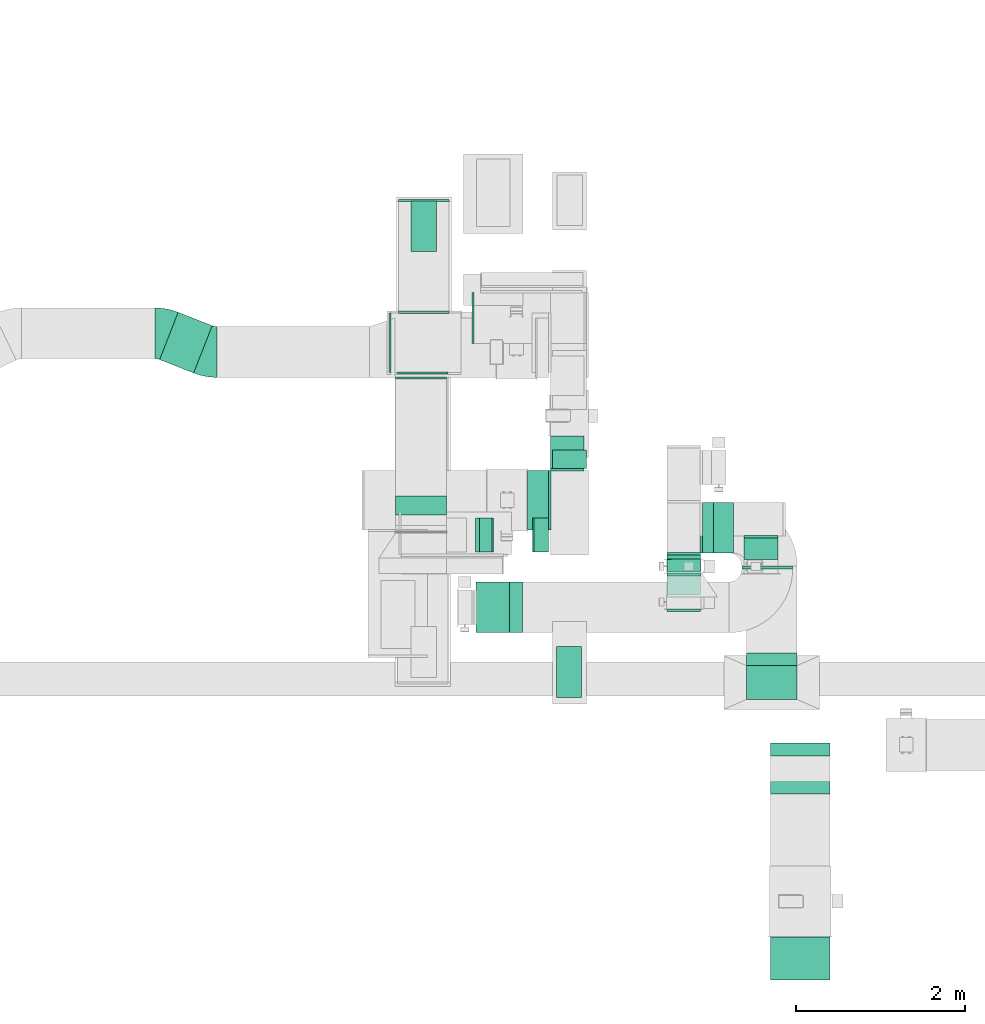
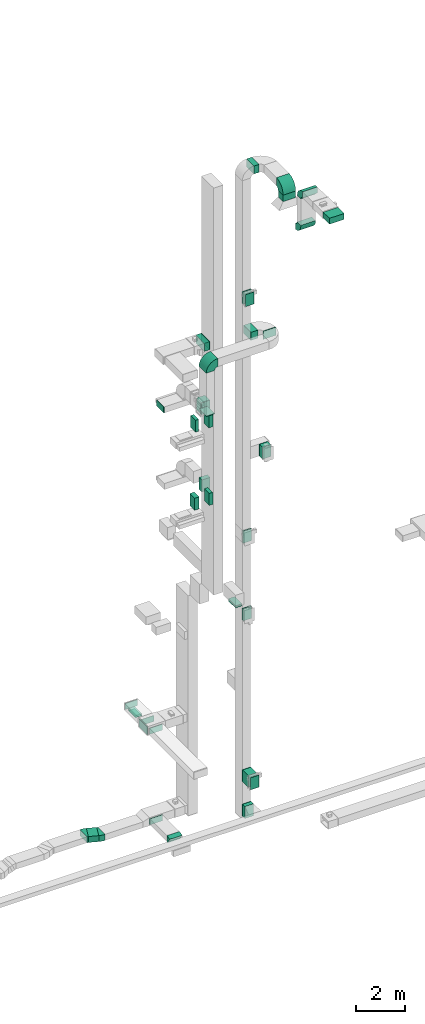
# One storey, part 13 of 29: 27 flow fittings, 21 flow segments, 1 flow terminal.
"""IFC2X3 building model written with IfcOpenShell, lengths in millimetres."""

from ifc_helpers import new_model, entity, si_unit, converted_unit, derived_unit, direction, frame, frame_2d, origin, origin_2d_with_axis, place, context, subcontext, project, spatial, polyline, circle_curve, parameter, trimmed, segment, composite_curve, rectangle, outline, extrude, source, transform, mapped, material, type_object, type_shapes, element, save


model = new_model("IFC2X3")

# Units and contexts
model_context = context("Model", 3, precision=0.01, world=origin(), true_north=direction((6.12303176911189e-17, 1.0)))
body_context = subcontext(model_context, "Body", "Model", "MODEL_VIEW")
ifc_project = project(units=[si_unit("LENGTHUNIT", "METRE", prefix="MILLI"), si_unit("AREAUNIT", "SQUARE_METRE"), si_unit("VOLUMEUNIT", "CUBIC_METRE"), converted_unit("PLANEANGLEUNIT", "DEGREE", entity("IfcRatioMeasure", 0.0174532925199433), si_unit("PLANEANGLEUNIT", "RADIAN"), dimensions=[0, 0, 0, 0, 0, 0, 0]), si_unit("MASSUNIT", "GRAM", prefix="KILO"), derived_unit("MASSDENSITYUNIT", [(si_unit("MASSUNIT", "GRAM", prefix="KILO"), 1), (si_unit("LENGTHUNIT", "METRE"), -3)]), derived_unit("MOMENTOFINERTIAUNIT", [(si_unit("LENGTHUNIT", "METRE"), 4)]), si_unit("TIMEUNIT", "SECOND"), si_unit("FREQUENCYUNIT", "HERTZ"), si_unit("THERMODYNAMICTEMPERATUREUNIT", "DEGREE_CELSIUS"), derived_unit("THERMALTRANSMITTANCEUNIT", [(si_unit("MASSUNIT", "GRAM", prefix="KILO"), 1), (si_unit("THERMODYNAMICTEMPERATUREUNIT", "KELVIN"), -1), (si_unit("TIMEUNIT", "SECOND"), -3)]), derived_unit("VOLUMETRICFLOWRATEUNIT", [(si_unit("LENGTHUNIT", "METRE"), 3), (si_unit("TIMEUNIT", "SECOND"), -1)]), derived_unit("MASSFLOWRATEUNIT", [(si_unit("MASSUNIT", "GRAM", prefix="KILO"), 1), (si_unit("TIMEUNIT", "SECOND"), -1)]), derived_unit("ROTATIONALFREQUENCYUNIT", [(si_unit("TIMEUNIT", "SECOND"), -1)]), si_unit("ELECTRICCURRENTUNIT", "AMPERE"), si_unit("ELECTRICVOLTAGEUNIT", "VOLT"), si_unit("POWERUNIT", "WATT"), si_unit("FORCEUNIT", "NEWTON", prefix="KILO"), si_unit("ILLUMINANCEUNIT", "LUX"), si_unit("LUMINOUSFLUXUNIT", "LUMEN"), si_unit("LUMINOUSINTENSITYUNIT", "CANDELA"), derived_unit("USERDEFINED", [(si_unit("MASSUNIT", "GRAM", prefix="KILO"), -1), (si_unit("LENGTHUNIT", "METRE"), -2), (si_unit("TIMEUNIT", "SECOND"), 3), (si_unit("LUMINOUSFLUXUNIT", "LUMEN"), 1)]), derived_unit("LINEARVELOCITYUNIT", [(si_unit("LENGTHUNIT", "METRE"), 1), (si_unit("TIMEUNIT", "SECOND"), -1)]), si_unit("PRESSUREUNIT", "PASCAL"), derived_unit("USERDEFINED", [(si_unit("LENGTHUNIT", "METRE"), -2), (si_unit("MASSUNIT", "GRAM", prefix="KILO"), 1), (si_unit("TIMEUNIT", "SECOND"), -2)]), derived_unit("LINEARFORCEUNIT", [(si_unit("MASSUNIT", "GRAM", prefix="KILO"), 1), (si_unit("LENGTHUNIT", "METRE"), 1), (si_unit("TIMEUNIT", "SECOND"), -2), (si_unit("LENGTHUNIT", "METRE"), -1)]), derived_unit("PLANARFORCEUNIT", [(si_unit("MASSUNIT", "GRAM", prefix="KILO"), 1), (si_unit("LENGTHUNIT", "METRE"), 1), (si_unit("TIMEUNIT", "SECOND"), -2), (si_unit("LENGTHUNIT", "METRE"), -2)])], contexts=[model_context])

# Site, building, storey
site_placement = place(None, frame((0.0, -0.00077364408347762, 0.0)))
site = spatial("IfcSite", under=ifc_project, at=site_placement, CompositionType="ELEMENT")
building_placement = place(site_placement, origin())
building = spatial("IfcBuilding", under=site, at=building_placement, CompositionType="ELEMENT")
storey_placement = place(building_placement, origin())
storey = spatial("IfcBuildingStorey", under=building, at=storey_placement, CompositionType="ELEMENT", Elevation=0.0)

# Flow segments
duct_segment_type = type_object("IfcDuctSegmentType", PredefinedType="NOTDEFINED")
flow_segment_1_placement = place(storey_placement, frame((30023.9052184742, 10939.6152449868, 22300.0)))
element("IfcFlowSegment", 1, at=flow_segment_1_placement, inside=storey, type_object=duct_segment_type, context=body_context, shape_type="SweptSolid", body=[
    extrude(rectangle(XDim=251.096000000203, YDim=699.999999999999, at=frame_2d((2.16715534406831e-12, 1.08002495835535e-12), x_axis=(1.0, 0.0))), frame((125.548000000099, 350.0, 0.0)), (0.0, 0.0, 1.0), 399.999999999996),
])
flow_segment_2_placement = place(storey_placement, frame((29456.9164691885, 10677.382032688, 18600.0)))
element("IfcFlowSegment", 2, at=flow_segment_2_placement, inside=storey, type_object=duct_segment_type, context=body_context, shape_type="SweptSolid", body=[
    extrude(rectangle(XDim=150.000000000005, YDim=400.0, at=frame_2d((-2.16715534406831e-12, 0.0), x_axis=(1.0, 0.0))), frame((75.0, 200.0, 0.0), z_axis=(0.0, 0.0, 1.0), x_axis=(-1.0, 0.0, 0.0)), (0.0, 0.0, 1.0), 599.999999999998),
])
flow_segment_3_placement = place(storey_placement, frame((30086.9164691886, 10677.382032688, 18600.0)))
element("IfcFlowSegment", 3, at=flow_segment_3_placement, inside=storey, type_object=duct_segment_type, context=body_context, shape_type="SweptSolid", body=[
    extrude(rectangle(XDim=188.084749285835, YDim=400.0, at=frame_2d((-2.16715534406831e-12, 0.0), x_axis=(1.0, 0.0))), frame((94.0423746429199, 200.0, 0.0), z_axis=(0.0, 0.0, 1.0), x_axis=(-1.0, 0.0, 0.0)), (0.0, 0.0, 1.0), 600.000000000002),
])
flow_segment_4_placement = place(storey_placement, frame((30101.9164691886, 10677.382032688, 14700.0)))
element("IfcFlowSegment", 4, at=flow_segment_4_placement, inside=storey, type_object=duct_segment_type, context=body_context, shape_type="SweptSolid", body=[
    extrude(rectangle(XDim=173.084749285813, YDim=400.0, at=frame_2d((2.1600499167107e-12, 0.0), x_axis=(1.0, 0.0))), frame((86.5423746429043, 200.0, 0.0), z_axis=(0.0, 0.0, 1.0), x_axis=(-1.0, 0.0, 0.0)), (0.0, 0.0, 1.0), 600.000000000002),
])
flow_segment_5_placement = place(storey_placement, frame((30365.0012184742, 8960.32523278362, 10500.0)))
element("IfcFlowSegment", 5, at=flow_segment_5_placement, inside=storey, type_object=duct_segment_type, context=body_context, shape_type="SweptSolid", body=[
    extrude(rectangle(XDim=300.000000000001, YDim=600.0, at=origin_2d_with_axis()), frame((150.0, 300.0, 0.0)), (0.0, 0.0, 1.0), 79.9999999999688),
])
flow_segment_6_placement = place(storey_placement, frame((30320.0012184742, 11661.5757001357, 14700.0)))
element("IfcFlowSegment", 6, at=flow_segment_6_placement, inside=storey, type_object=duct_segment_type, context=body_context, shape_type="SweptSolid", body=[
    extrude(rectangle(XDim=221.175631375204, YDim=400.0, at=frame_2d((-1.08002495835535e-12, 0.0), x_axis=(1.0, 0.0))), frame((200.0, 110.587815687765, 0.0), z_axis=(0.0, 0.0, 1.0), x_axis=(0.0, 1.0, 0.0)), (0.0, 0.0, 1.0), 600.000000000002),
])
flow_segment_7_placement = place(storey_placement, frame((30295.0012184743, 11661.8364765241, 18600.0)))
element("IfcFlowSegment", 7, at=flow_segment_7_placement, inside=storey, type_object=duct_segment_type, context=body_context, shape_type="SweptSolid", body=[
    extrude(rectangle(XDim=384.504473210767, YDim=400.0, at=frame_2d((1.09423581307055e-12, 0.0), x_axis=(1.0, 0.0))), frame((200.0, 192.25223660548, 0.0), z_axis=(0.0, 0.0, 1.0), x_axis=(0.0, -1.0, 0.0)), (0.0, 0.0, 1.0), 600.000000000002),
])
flow_segment_8_placement = place(storey_placement, frame((28651.0506788633, 14225.0082537764, 2400.0)))
element("IfcFlowSegment", 8, at=flow_segment_8_placement, inside=storey, type_object=duct_segment_type, context=body_context, shape_type="SweptSolid", body=[
    extrude(rectangle(XDim=599.999999999998, YDim=300.000000000001, at=frame_2d((-1.08002495835535e-12, 0.0), x_axis=(1.0, 0.0))), frame((150.0, 300.0, 0.0), z_axis=(0.0, 0.0, 1.0), x_axis=(0.0, 1.0, 0.0)), (0.0, 0.0, 1.0), 79.9999999999699),
])
flow_segment_9_placement = place(storey_placement, frame((32219.8749445683, 10665.0950531597, 30605.4908940358)))
element("IfcFlowSegment", 9, at=flow_segment_9_placement, inside=storey, type_object=duct_segment_type, context=body_context, shape_type="SweptSolid", body=[
    extrude(rectangle(XDim=239.145151963278, YDim=600.0, at=frame_2d((0.0, 1.08002495835535e-12), x_axis=(1.0, 0.0))), frame((119.572575981639, 300.0, 0.0)), (0.0, 0.0, 1.0), 399.999999999996),
])
flow_segment_10_placement = place(storey_placement, frame((31669.8749543007, 10592.3611346102, 24300.0)))
element("IfcFlowSegment", 10, at=flow_segment_10_placement, inside=storey, type_object=duct_segment_type, context=body_context, shape_type="SweptSolid", body=[
    extrude(rectangle(XDim=52.6715277765037, YDim=400.000000000002, at=frame_2d((-1.77635683940025e-15, -4.33431068813661e-12), x_axis=(1.0, 0.0))), frame((200.008206148523, 26.3981559428123, 0.0), z_axis=(0.0, 0.0, 1.0), x_axis=(0.000311966680507818, -0.999999951338394, 0.0)), (0.0, 0.0, 1.0), 600.000000000002),
])
flow_segment_11_placement = place(storey_placement, frame((32089.8749445684, 10665.0950531597, 22300.0)))
element("IfcFlowSegment", 11, at=flow_segment_11_placement, inside=storey, type_object=duct_segment_type, context=body_context, shape_type="SweptSolid", body=[
    extrude(rectangle(XDim=315.331551336668, YDim=600.0, at=frame_2d((2.1600499167107e-12, 1.08002495835535e-12), x_axis=(1.0, 0.0))), frame((157.665775668336, 300.0, 0.0), z_axis=(0.0, 0.0, 1.0), x_axis=(-1.0, 0.0, 0.0)), (0.0, 0.0, 1.0), 399.999999999996),
])
flow_segment_12_placement = place(storey_placement, frame((32555.206495905, 10474.9425362381, 22300.0)))
element("IfcFlowSegment", 12, at=flow_segment_12_placement, inside=storey, type_object=duct_segment_type, context=body_context, shape_type="SweptSolid", body=[
    extrude(rectangle(XDim=40.1525169212813, YDim=600.000000000002, at=origin_2d_with_axis()), frame((300.0, 20.0762584608995, 0.0), z_axis=(0.0, 0.0, 1.0), x_axis=(0.0, 1.0, 0.0)), (0.0, 0.0, 1.0), 399.999999999996),
])
flow_segment_13_placement = place(storey_placement, frame((32581.6142462298, 10592.0421268196, 16200.0)))
element("IfcFlowSegment", 13, at=flow_segment_13_placement, inside=storey, type_object=duct_segment_type, context=body_context, shape_type="SweptSolid", body=[
    extrude(rectangle(XDim=253.039939388961, YDim=399.999999999998, at=frame_2d((0.0, -2.17426077142591e-12), x_axis=(1.0, 0.0))), frame((200.008215459153, 126.5329569124, 0.0), z_axis=(0.0, 0.0, 1.0), x_axis=(6.49374233861676e-05, -0.999999997891566, 0.0)), (0.0, 0.0, 1.0), 599.999999999998),
])
flow_segment_14_placement = place(storey_placement, frame((31669.8796384443, 10594.9524921079, 12300.0)))
element("IfcFlowSegment", 14, at=flow_segment_14_placement, inside=storey, type_object=duct_segment_type, context=body_context, shape_type="SweptSolid", body=[
    extrude(rectangle(XDim=50.0956791701616, YDim=400.000000000001, at=frame_2d((2.16537898722891e-12, 2.1600499167107e-12), x_axis=(1.0, 0.0))), frame((200.005866195224, 25.0947227044576, 0.0), z_axis=(0.0, 0.0, 1.0), x_axis=(0.000234419037960343, -0.999999972523857, 0.0)), (0.0, 0.0, 1.0), 599.999999999998),
])
flow_segment_15_placement = place(storey_placement, frame((31669.8749446897, 10172.2318814283, 300.0)))
element("IfcFlowSegment", 15, at=flow_segment_15_placement, inside=storey, type_object=duct_segment_type, context=body_context, shape_type="SweptSolid", body=[
    extrude(rectangle(XDim=471.797025863042, YDim=400.000000000001, at=frame_2d((-1.08002495835535e-12, 4.33431068813661e-12), x_axis=(1.0, 0.0))), frame((200.008215759532, 235.905478394751, 0.0), z_axis=(0.0, 0.0, 1.0), x_axis=(3.48280314986155e-05, -1.0, 0.0)), (0.0, 0.0, 1.0), 600.0),
])
flow_segment_16_placement = place(storey_placement, frame((31669.8749445682, 10445.0, -1425.0)))
element("IfcFlowSegment", 16, at=flow_segment_16_placement, inside=storey, type_object=duct_segment_type, context=body_context, shape_type="SweptSolid", body=[
    extrude(rectangle(XDim=200.095053159419, YDim=400.0, at=frame_2d((0.0, -2.17426077142591e-12), x_axis=(1.0, 0.0))), frame((200.0, 100.04752657971, 0.0), z_axis=(0.0, 0.0, 1.0), x_axis=(0.0, 1.0, 0.0)), (0.0, 0.0, 1.0), 600.0),
])
flow_segment_17_placement = place(storey_placement, frame((32894.0200965316, 5624.99997688055, 30900.0)))
element("IfcFlowSegment", 17, at=flow_segment_17_placement, inside=storey, type_object=duct_segment_type, context=body_context, shape_type="SweptSolid", body=[
    extrude(rectangle(XDim=507.958451099597, YDim=700.000000000001, at=frame_2d((0.0, 2.1600499167107e-12), x_axis=(1.0, 0.0))), frame((350.0, 253.979225549798, 0.0), z_axis=(0.0, 0.0, 1.0), x_axis=(0.0, -1.0, 0.0)), (0.0, 0.0, 1.0), 300.000000000001),
])
flow_segment_18_placement = place(storey_placement, frame((32609.0200965316, 8936.91252370865, 30130.0)))
element("IfcFlowSegment", 18, at=flow_segment_18_placement, inside=storey, type_object=duct_segment_type, context=body_context, shape_type="SweptSolid", body=[
    extrude(rectangle(XDim=600.000000000002, YDim=400.0, at=origin_2d_with_axis()), frame((300.0, 200.0, 0.0)), (0.0, 0.0, 1.0), 325.490894035817),
])
flow_segment_19_placement = place(storey_placement, frame((31669.8796640619, 10595.3322733193, 8400.0)))
element("IfcFlowSegment", 19, at=flow_segment_19_placement, inside=storey, type_object=duct_segment_type, context=body_context, shape_type="SweptSolid", body=[
    extrude(rectangle(XDim=49.715642394297, YDim=400.000000000001, at=frame_2d((-3.5527136788005e-15, -2.1600499167107e-12), x_axis=(1.0, 0.0))), frame((200.005853356414, 24.904959889241, 0.0), z_axis=(0.0, 0.0, 1.0), x_axis=(-0.00023569691278059, 0.999999972223482, 0.0)), (0.0, 0.0, 1.0), 600.0),
])
flow_segment_20_placement = place(storey_placement, frame((29411.9164691886, 10677.382032688, 14700.0)))
element("IfcFlowSegment", 20, at=flow_segment_20_placement, inside=storey, type_object=duct_segment_type, context=body_context, shape_type="SweptSolid", body=[
    extrude(rectangle(XDim=210.000000000009, YDim=400.0, at=frame_2d((-2.16715534406831e-12, 0.0), x_axis=(1.0, 0.0))), frame((105.0, 200.0, 0.0), z_axis=(0.0, 0.0, 1.0), x_axis=(-1.0, 0.0, 0.0)), (0.0, 0.0, 1.0), 600.000000000002),
])
flow_segment_21_placement = place(storey_placement, frame((25682.1061865058, 12791.5830765503, -2050.0)))
element("IfcFlowSegment", 21, at=flow_segment_21_placement, inside=storey, type_object=duct_segment_type, context=body_context, shape_type="SweptSolid", body=[
    extrude(rectangle(XDim=431.766619119169, YDim=600.000000000001, at=frame_2d((-1.60582658281783e-12, -1.81898940354586e-12), x_axis=(1.0, 0.0))), frame((310.5745647305, 358.13869361976, 0.0), z_axis=(0.0, 0.0, 1.0), x_axis=(-0.930851591492938, 0.365397474834002, 0.0)), (0.0, 0.0, 1.0), 300.0),
])

# Flow fittings
ifc_material_1 = material()
duct_fitting_type_1 = type_object("IfcDuctFittingType", PredefinedType="NOTDEFINED", material=ifc_material_1)
shared_shape_1 = source(origin(), body_context, "Body", "SweptSolid", [
    extrude(rectangle(XDim=24.9999999999999, YDim=700.0, at=frame_2d((-2.89546164822241e-13, 5.6843418860808e-14), x_axis=(1.0, 0.0))), frame((12.500000000006, 0.0, -200.0)), (0.0, 0.0, 1.0), 400.0),
])
type_shapes(duct_fitting_type_1, [shared_shape_1])
flow_fitting_1_placement = place(storey_placement, frame((28415.0012184742, 13147.7217701701, 2700.0), z_axis=(0.0, 0.0, 1.0), x_axis=(-1.0, 0.0, 0.0)))
element("IfcFlowFitting", 22, at=flow_fitting_1_placement, inside=storey, type_object=duct_fitting_type_1, material=ifc_material_1, context=body_context, shape_type="MappedRepresentation", body=[
    mapped(shared_shape_1, transform((0.0, 0.0, 0.0), scale=1.0)),
])
duct_fitting_type_2 = type_object("IfcDuctFittingType", PredefinedType="NOTDEFINED", material=ifc_material_1)
shared_shape_2 = source(origin(), body_context, "Body", "SweptSolid", [
    extrude(rectangle(XDim=26.0960000000006, YDim=400.0, at=frame_2d((-3.10862446895044e-13, -1.4210854715202e-13), x_axis=(1.0, 0.0))), frame((6.95199999999999, 0.0, -350.0)), (0.0, 0.0, 1.0), 700.0),
])
type_shapes(duct_fitting_type_2, [shared_shape_2])
for number, where, z_axis, x_axis in (
    (23, (30295.0012184744, 11292.6152449868, 22500.0), (0.0, 1.0, 0.0), (-1.0, 0.0, 0.0)),
    (24, (30295.0012184744, 11289.6152449868, 22500.0), (0.0, 1.0, 0.0), (-1.0, 0.0, 0.0)),
):
    element("IfcFlowFitting", number, at=place(storey_placement, frame(where, z_axis=z_axis, x_axis=x_axis)), inside=storey, type_object=duct_fitting_type_2, material=ifc_material_1, context=body_context, shape_type="MappedRepresentation", body=[
        mapped(shared_shape_2, transform((0.0, 0.0, 0.0), scale=1.0)),
    ])
duct_fitting_type_3 = type_object("IfcDuctFittingType", PredefinedType="NOTDEFINED", material=ifc_material_1)
shared_shape_3 = source(origin(), body_context, "Body", "SweptSolid", [
    extrude(rectangle(XDim=26.0960000000009, YDim=600.0, at=frame_2d((-4.66293670342566e-13, -1.4210854715202e-13), x_axis=(1.0, 0.0))), frame((6.95199999999999, 0.0, -200.0)), (0.0, 0.0, 1.0), 400.0),
])
type_shapes(duct_fitting_type_3, [shared_shape_3])
flow_fitting_2_placement = place(storey_placement, frame((31869.8749445684, 10665.0950531597, 24600.0), z_axis=(-1.0, 0.0, 0.0), x_axis=(0.0, -1.0, 0.0)))
element("IfcFlowFitting", 25, at=flow_fitting_2_placement, inside=storey, type_object=duct_fitting_type_3, material=ifc_material_1, context=body_context, shape_type="MappedRepresentation", body=[
    mapped(shared_shape_3, transform((0.0, 0.0, 0.0), scale=1.0)),
])
duct_fitting_type_4 = type_object("IfcDuctFittingType", PredefinedType="NOTDEFINED", material=ifc_material_1)
shared_shape_4 = source(origin(), body_context, "Body", "SweptSolid", [
    extrude(rectangle(XDim=24.9999999999999, YDim=400.0, at=frame_2d((-1.63424829224823e-13, 0.0), x_axis=(1.0, 0.0))), frame((12.5000000000061, 0.0, -300.0)), (0.0, 0.0, 1.0), 600.0),
])
type_shapes(duct_fitting_type_4, [shared_shape_4])
for number, where, z_axis, x_axis in (
    (26, (31869.8749445684, 10422.4235279463, 24600.0), (0.0, 0.0, 1.0), (0.0, -1.0, 0.0)),
    (27, (31869.8749445684, 10002.2388470346, 600.0), (0.0, 0.0, 1.0), (0.0, -1.0, 0.0)),
):
    element("IfcFlowFitting", number, at=place(storey_placement, frame(where, z_axis=z_axis, x_axis=x_axis)), inside=storey, type_object=duct_fitting_type_4, material=ifc_material_1, context=body_context, shape_type="MappedRepresentation", body=[
        mapped(shared_shape_4, transform((0.0, 0.0, 0.0), scale=1.0)),
    ])
duct_fitting_type_5 = type_object("IfcDuctFittingType", PredefinedType="NOTDEFINED", material=ifc_material_1)
shared_shape_5 = source(origin(), body_context, "Body", "SweptSolid", [
    extrude(rectangle(XDim=26.0960000000291, YDim=600.0, at=frame_2d((-4.67181848762266e-13, -1.4210854715202e-13), x_axis=(1.0, 0.0))), frame((6.95199999999891, 0.0, -150.0)), (0.0, 0.0, 1.0), 300.0),
])
type_shapes(duct_fitting_type_5, [shared_shape_5])
for number, where, z_axis, x_axis in (
    (28, (28801.0506788633, 13497.7217701701, 2650.0), (0.0, 0.0, -1.0), (0.0, 1.0, 0.0)),
    (29, (30515.0012184742, 9260.32523278362, 10600.0), (1.0, 0.0, 0.0), (0.0, 0.0, -1.0)),
):
    element("IfcFlowFitting", number, at=place(storey_placement, frame(where, z_axis=z_axis, x_axis=x_axis)), inside=storey, type_object=duct_fitting_type_5, material=ifc_material_1, context=body_context, shape_type="MappedRepresentation", body=[
        mapped(shared_shape_5, transform((0.0, 0.0, 0.0), scale=1.0)),
    ])
duct_fitting_type_6 = type_object("IfcDuctFittingType", PredefinedType="NOTDEFINED", material=ifc_material_1)
shared_shape_6 = source(origin(), body_context, "Body", "SweptSolid", [
    extrude(rectangle(XDim=24.9999999999999, YDim=600.0, at=frame_2d((-2.46913600676635e-13, 0.0), x_axis=(1.0, 0.0))), frame((12.500000000006, 0.0, -150.0)), (0.0, 0.0, 1.0), 300.0),
])
type_shapes(duct_fitting_type_6, [shared_shape_6])
for number, where, z_axis, x_axis in (
    (30, (28801.0506788633, 14817.2399163586, 2650.0), (0.0, 0.0, 1.0), (0.0, 1.0, 0.0)),
    (31, (29393.9378229566, 13442.3820326881, 18250.0), (0.0, 0.0, 1.0), (-1.0, 0.0, 0.0)),
):
    element("IfcFlowFitting", number, at=place(storey_placement, frame(where, z_axis=z_axis, x_axis=x_axis)), inside=storey, type_object=duct_fitting_type_6, material=ifc_material_1, context=body_context, shape_type="MappedRepresentation", body=[
        mapped(shared_shape_6, transform((0.0, 0.0, 0.0), scale=1.0)),
    ])
duct_fitting_type_7 = type_object("IfcDuctFittingType", PredefinedType="NOTDEFINED", material=ifc_material_1)
shared_shape_7 = source(origin(), body_context, "Body", "SweptSolid", [
    extrude(rectangle(XDim=300.0, YDim=26.0960000000498, at=frame_2d((-2.8421709430404e-14, 0.0), x_axis=(1.0, 0.0))), frame((6.95200000000595, 0.0, -300.0), z_axis=(0.0, 0.0, 1.0), x_axis=(0.0, -1.0, 0.0)), (0.0, 0.0, 1.0), 600.0),
])
type_shapes(duct_fitting_type_7, [shared_shape_7])
flow_fitting_3_placement = place(storey_placement, frame((28801.0506788633, 14525.0082537764, 2500.0), z_axis=(0.0, 1.0, 0.0), x_axis=(0.0, 0.0, -1.0)))
element("IfcFlowFitting", 32, at=flow_fitting_3_placement, inside=storey, type_object=duct_fitting_type_7, material=ifc_material_1, context=body_context, shape_type="MappedRepresentation", body=[
    mapped(shared_shape_7, transform((0.0, 0.0, 0.0), scale=1.0)),
])
duct_fitting_type_8 = type_object("IfcDuctFittingType", PredefinedType="NOTDEFINED", material=ifc_material_1)
shared_shape_8 = source(origin(), body_context, "Body", "SweptSolid", [
    extrude(rectangle(XDim=600.0, YDim=26.0960000000493, at=origin_2d_with_axis()), frame((6.95199999999999, 0.0, -150.0), z_axis=(0.0, 0.0, 1.0), x_axis=(0.0, -1.0, 0.0)), (0.0, 0.0, 1.0), 300.0),
])
type_shapes(duct_fitting_type_8, [shared_shape_8])
for number, where, z_axis, x_axis in (
    (33, (28789.0983074609, 12797.7217701701, 2650.0), (0.0, 0.0, -1.0), (0.0, -1.0, 0.0)),
    (34, (28769.9546456568, 12739.7217701699, -1850.0), (0.0, 0.0, -1.0), (0.0, -1.0, 0.0)),
):
    element("IfcFlowFitting", number, at=place(storey_placement, frame(where, z_axis=z_axis, x_axis=x_axis)), inside=storey, type_object=duct_fitting_type_8, material=ifc_material_1, context=body_context, shape_type="MappedRepresentation", body=[
        mapped(shared_shape_8, transform((0.0, 0.0, 0.0), scale=1.0)),
    ])

# Flow terminal
ifc_material_2 = material()
air_terminal_type = type_object("IfcAirTerminalType", PredefinedType="NOTDEFINED", material=ifc_material_2)
shared_shape_9 = source(origin(), body_context, "Body", "SweptSolid", [
    extrude(rectangle(XDim=4.0, YDim=599.999999999999, at=origin_2d_with_axis()), frame((0.0, -2.0, -150.0), z_axis=(0.0, 0.0, 1.0), x_axis=(0.0, 1.0, 0.0)), (0.0, 0.0, 1.0), 300.000000000005),
])
type_shapes(air_terminal_type, [shared_shape_9])
flow_terminal_placement = place(storey_placement, frame((28801.0506788633, 14525.0082537764, 2400.0), z_axis=(-1.0, 0.0, 0.0), x_axis=(0.0, -1.0, 0.0)))
element("IfcFlowTerminal", 35, at=flow_terminal_placement, inside=storey, type_object=air_terminal_type, material=ifc_material_2, context=body_context, shape_type="MappedRepresentation", body=[
    mapped(shared_shape_9, transform((0.0, 0.0, 0.0), scale=1.0)),
])

# Flow fittings
duct_fitting_type_9 = type_object("IfcDuctFittingType", PredefinedType="NOTDEFINED", material=ifc_material_1)
shared_shape_10 = source(origin(), body_context, "Body", "SweptSolid", [
    extrude(rectangle(XDim=24.9999999999999, YDim=600.0, at=frame_2d((-2.46913600676635e-13, 0.0), x_axis=(1.0, 0.0))), frame((12.500000000006, 0.0, -200.0)), (0.0, 0.0, 1.0), 400.0),
])
type_shapes(duct_fitting_type_9, [shared_shape_10])
flow_fitting_4_placement = place(storey_placement, frame((29615.5638771012, 10024.9425362384, 20000.0), z_axis=(1.0, 0.0, 0.0), x_axis=(0.0, 0.0, -1.0)))
element("IfcFlowFitting", 36, at=flow_fitting_4_placement, inside=storey, type_object=duct_fitting_type_9, material=ifc_material_1, context=body_context, shape_type="MappedRepresentation", body=[
    mapped(shared_shape_10, transform((0.0, 0.0, 0.0), scale=1.0)),
])
duct_fitting_type_10 = type_object("IfcDuctFittingType", PredefinedType="NOTDEFINED", material=ifc_material_1)
shared_shape_11 = source(origin(), body_context, "Body", "SweptSolid", [
    extrude(rectangle(XDim=600.0, YDim=26.096, at=origin_2d_with_axis()), frame((6.95199999999999, 0.0, -200.0), z_axis=(0.0, 0.0, 1.0), x_axis=(0.0, -1.0, 0.0)), (0.0, 0.0, 1.0), 400.0),
])
type_shapes(duct_fitting_type_10, [shared_shape_11])
for number, where, z_axis, x_axis in (
    (37, (31869.8749445684, 10665.0950531597, 8700.0), (-1.0, 0.0, 0.0), (0.0, -1.0, 0.0)),
    (38, (31869.8749445682, 10665.0950531597, -1125.0), (-1.0, 0.0, 0.0), (0.0, -1.0, 0.0)),
):
    element("IfcFlowFitting", number, at=place(storey_placement, frame(where, z_axis=z_axis, x_axis=x_axis)), inside=storey, type_object=duct_fitting_type_10, material=ifc_material_1, context=body_context, shape_type="MappedRepresentation", body=[
        mapped(shared_shape_11, transform((0.0, 0.0, 0.0), scale=1.0)),
    ])
duct_fitting_type_11 = type_object("IfcDuctFittingType", PredefinedType="NOTDEFINED", material=ifc_material_1)
shared_shape_12 = source(origin(), body_context, "Body", "SweptSolid", [
    extrude(rectangle(XDim=26.0960000000093, YDim=400.0, at=frame_2d((-3.10862446895044e-13, -1.4210854715202e-13), x_axis=(1.0, 0.0))), frame((6.95199999999999, 0.0, -300.0)), (0.0, 0.0, 1.0), 600.0),
])
type_shapes(duct_fitting_type_11, [shared_shape_12])
for number, where, z_axis, x_axis in (
    (39, (32069.8749445684, 10965.0950531597, 22500.0), (0.0, -1.0, 0.0), (1.0, 0.0, 0.0)),
    (40, (32781.6142458081, 10865.0950531597, 16500.0), (0.0, 0.0, -1.0), (0.0, -1.0, 0.0)),
):
    element("IfcFlowFitting", number, at=place(storey_placement, frame(where, z_axis=z_axis, x_axis=x_axis)), inside=storey, type_object=duct_fitting_type_11, material=ifc_material_1, context=body_context, shape_type="MappedRepresentation", body=[
        mapped(shared_shape_12, transform((0.0, 0.0, 0.0), scale=1.0)),
    ])
duct_fitting_type_12 = type_object("IfcDuctFittingType", PredefinedType="NOTDEFINED", material=ifc_material_1)
shared_shape_13 = source(origin(), body_context, "Body", "SweptSolid", [
    extrude(outline(composite_curve([segment(polyline([(-375.0, -175.0), (25.0, -175.0)]), True, "CONTINUOUS"), segment(trimmed(circle_curve(frame_2d((175.0, -175.0), x_axis=(0.0, 1.0)), 150.0), [parameter(0.0)], [parameter(90.0000000000001)], True, "PARAMETER"), False, "CONTINUOUS"), segment(polyline([(175.0, -25.0), (175.0, 375.0)]), True, "CONTINUOUS"), segment(trimmed(circle_curve(frame_2d((175.0, -175.0), x_axis=(0.0, 1.0)), 550.0), [parameter(0.0)], [parameter(90.0)], True, "PARAMETER"), True, "CONTINUOUS")], self_intersect=False)), frame((-175.0, 175.0, -300.0), z_axis=(0.0, 0.0, 1.0), x_axis=(-1.0, 0.0, 0.0)), (0.0, 0.0, 1.0), 600.0),
])
type_shapes(duct_fitting_type_12, [shared_shape_13])
for number, where, z_axis, x_axis in (
    (41, (29615.5638771013, 10024.9425362384, 22500.0), (0.0, -1.0, 0.0), (-1.0, 0.0, 0.0)),
    (42, (32909.0200965316, 9136.91252370959, 30805.4908940359), (1.0, 0.0, 0.0), (0.0, -1.0, 0.0)),
):
    element("IfcFlowFitting", number, at=place(storey_placement, frame(where, z_axis=z_axis, x_axis=x_axis)), inside=storey, type_object=duct_fitting_type_12, material=ifc_material_1, context=body_context, shape_type="MappedRepresentation", body=[
        mapped(shared_shape_13, transform((0.0, 0.0, 0.0), scale=1.0)),
    ])
duct_fitting_type_13 = type_object("IfcDuctFittingType", PredefinedType="NOTDEFINED", material=ifc_material_1)
shared_shape_14 = source(origin(), body_context, "Body", "SweptSolid", [
    extrude(rectangle(XDim=28.2143610964482, YDim=600.0, at=frame_2d((-4.63629135083465e-13, -1.4210854715202e-13), x_axis=(1.0, 0.0))), frame((6.95199999999999, 0.0, -200.0)), (0.0, 0.0, 1.0), 400.0),
])
type_shapes(duct_fitting_type_13, [shared_shape_14])
flow_fitting_5_placement = place(storey_placement, frame((31869.8749445684, 10665.0950531597, 600.0), z_axis=(-1.0, 0.0, 0.0), x_axis=(0.0, -1.0, 0.0)))
element("IfcFlowFitting", 43, at=flow_fitting_5_placement, inside=storey, type_object=duct_fitting_type_13, material=ifc_material_1, context=body_context, shape_type="MappedRepresentation", body=[
    mapped(shared_shape_14, transform((0.0, 0.0, 0.0), scale=1.0)),
])
duct_fitting_type_14 = type_object("IfcDuctFittingType", PredefinedType="NOTDEFINED", material=ifc_material_1)
shared_shape_15 = source(origin(), body_context, "Body", "SweptSolid", [
    extrude(outline(composite_curve([segment(polyline([(-300.0, -150.0), (0.0, -150.0)]), True, "CONTINUOUS"), segment(trimmed(circle_curve(frame_2d((150.0, -150.0), x_axis=(0.0, 1.0)), 150.0), [parameter(0.0)], [parameter(90.0)], True, "PARAMETER"), False, "CONTINUOUS"), segment(polyline([(150.0, 0.0), (150.0, 300.0)]), True, "CONTINUOUS"), segment(trimmed(circle_curve(frame_2d((150.0, -150.0), x_axis=(0.0, 1.0)), 450.0), [parameter(0.0)], [parameter(90.0000000000001)], True, "PARAMETER"), True, "CONTINUOUS")], self_intersect=False)), frame((-150.0, 150.0, -350.0), z_axis=(0.0, 0.0, 1.0), x_axis=(-1.0, 0.0, 0.0)), (0.0, 0.0, 1.0), 700.0),
])
type_shapes(duct_fitting_type_14, [shared_shape_15])
for number, where, z_axis, x_axis in (
    (44, (33244.0200965316, 8120.91132618237, 31050.0), (1.0, 0.0, 0.0), (0.0, 0.0, 1.0)),
    (45, (33244.0200965316, 8120.9113261824, 29120.0), (1.0, 0.0, 0.0), (0.0, 0.0, -1.0)),
):
    element("IfcFlowFitting", number, at=place(storey_placement, frame(where, z_axis=z_axis, x_axis=x_axis)), inside=storey, type_object=duct_fitting_type_14, material=ifc_material_1, context=body_context, shape_type="MappedRepresentation", body=[
        mapped(shared_shape_15, transform((0.0, 0.0, 0.0), scale=1.0)),
    ])
duct_fitting_type_15 = type_object("IfcDuctFittingType", PredefinedType="NOTDEFINED", material=ifc_material_1)
shared_shape_16 = source(origin(), body_context, "Body", "SweptSolid", [
    extrude(outline(composite_curve([segment(polyline([(-315.558391914087, -82.2144318376441), (284.441608085913, -82.2144318376441)]), True, "CONTINUOUS"), segment(trimmed(circle_curve(frame_2d((434.441608085913, -82.214431837644), x_axis=(-0.930851591492948, 0.365397474833975)), 150.0), [parameter(0.0)], [parameter(21.4320460265405)], True, "PARAMETER"), False, "CONTINUOUS"), segment(polyline([(294.813869361971, -27.4048106125478), (-263.697085533798, 191.833674287837)]), True, "CONTINUOUS"), segment(trimmed(circle_curve(frame_2d((434.441608085913, -82.214431837644), x_axis=(-0.930851591492948, 0.365397474833975)), 750.0), [parameter(0.0)], [parameter(21.4320460265405)], True, "PARAMETER"), True, "CONTINUOUS")], self_intersect=False)), frame((-2.94429522337152, 15.5583919140783, -150.0), z_axis=(0.0, 0.0, 1.0), x_axis=(-0.365397474833975, 0.930851591492948, 0.0)), (0.0, 0.0, 1.0), 300.0),
])
type_shapes(duct_fitting_type_15, [shared_shape_16])
for number, where, z_axis, x_axis in (
    (46, (25712.4552923417, 13259.7217701701, -1900.0), (0.0, 0.0, 1.0), (-0.930851591492938, 0.365397474834001, 0.0)),
    (47, (26272.9062101308, 13039.7217701701, -1900.0), (0.0, 0.0, 1.0), (0.930851591492938, -0.365397474834, 0.0)),
):
    element("IfcFlowFitting", number, at=place(storey_placement, frame(where, z_axis=z_axis, x_axis=x_axis)), inside=storey, type_object=duct_fitting_type_15, material=ifc_material_1, context=body_context, shape_type="MappedRepresentation", body=[
        mapped(shared_shape_16, transform((0.0, 0.0, 0.0), scale=1.0)),
    ])
duct_fitting_type_16 = type_object("IfcDuctFittingType", PredefinedType="NOTDEFINED", material=ifc_material_1)
shared_shape_17 = source(origin(), body_context, "Body", "SweptSolid", [
    extrude(outline(composite_curve([segment(polyline([(-170.096188393128, -74.9999982000424), (129.903811606872, -74.9999982000425)]), True, "CONTINUOUS"), segment(trimmed(circle_curve(frame_2d((279.903811606872, -74.9999982000425), x_axis=(-0.866025410712478, 0.499999988000285)), 150.0), [parameter(0.0)], [parameter(29.9999992061053)], True, "PARAMETER"), False, "CONTINUOUS"), segment(polyline([(150.0, 0.0), (-109.807623213743, 149.999996400086)]), True, "CONTINUOUS"), segment(trimmed(circle_curve(frame_2d((279.903811606872, -74.9999982000425), x_axis=(-0.866025410712478, 0.499999988000285)), 450.0), [parameter(0.0)], [parameter(29.9999992061053)], True, "PARAMETER"), True, "CONTINUOUS")], self_intersect=False)), frame((-5.38475730165266, 20.09618839312, -300.0), z_axis=(0.0, 0.0, 1.0), x_axis=(-0.499999988000285, 0.866025410712477, 0.0)), (0.0, 0.0, 1.0), 600.0),
])
type_shapes(duct_fitting_type_16, [shared_shape_17])
flow_fitting_6_placement = place(storey_placement, frame((28769.9546456568, 11256.9231567183, -1850.0), z_axis=(-1.0, 0.0, 0.0), x_axis=(0.0, 0.866025410712447, 0.499999988000337)))
element("IfcFlowFitting", 48, at=flow_fitting_6_placement, inside=storey, type_object=duct_fitting_type_16, material=ifc_material_1, context=body_context, shape_type="MappedRepresentation", body=[
    mapped(shared_shape_17, transform((0.0, 0.0, 0.0), scale=1.0)),
])
duct_fitting_type_17 = type_object("IfcDuctFittingType", PredefinedType="NOTDEFINED", material=ifc_material_1)
shared_shape_18 = source(origin(), body_context, "Body", "SweptSolid", [
    extrude(rectangle(XDim=26.1514803164612, YDim=600.0, at=frame_2d((-4.66293670342566e-13, -1.4210854715202e-13), x_axis=(1.0, 0.0))), frame((6.97974015823012, 0.0, -200.0)), (0.0, 0.0, 1.0), 400.0),
])
type_shapes(duct_fitting_type_17, [shared_shape_18])
flow_fitting_7_placement = place(storey_placement, frame((30495.0012184744, 11641.7809962077, 18900.0), z_axis=(1.0, 0.0, 0.0), x_axis=(0.0, 1.0, 0.0)))
element("IfcFlowFitting", 49, at=flow_fitting_7_placement, inside=storey, type_object=duct_fitting_type_17, material=ifc_material_1, context=body_context, shape_type="MappedRepresentation", body=[
    mapped(shared_shape_18, transform((0.0, 0.0, 0.0), scale=1.0)),
])

save(model, "model.ifc")
